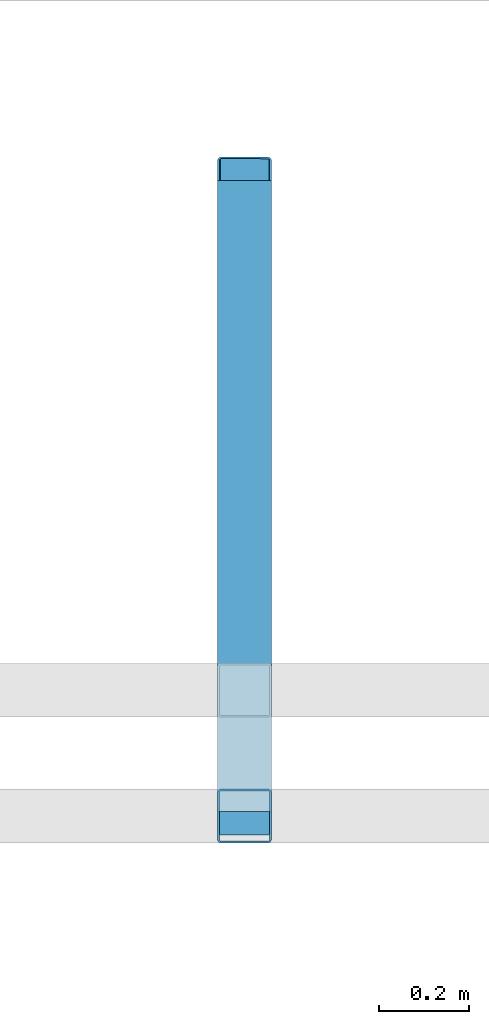
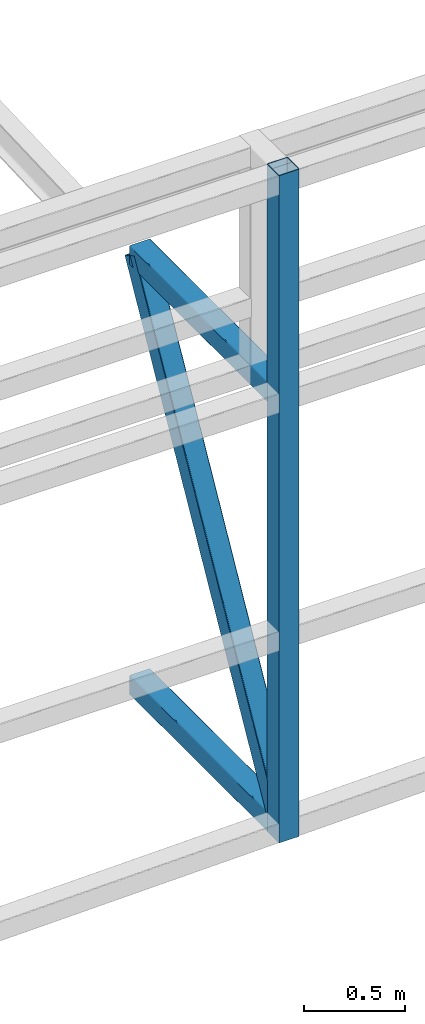
# One storey, part 107 of 215: 3 beams, 1 member, 4 elements without a shape of their own.
"""IFC2X3 building model written with IfcOpenShell, lengths in millimetres."""

from ifc_helpers import new_model, si_unit, frame, origin_with_axes, origin_2d_with_axis, place, context, subcontext, project, spatial, hollow_rectangle, extrude, material, type_object, element, aggregate, save


model = new_model("IFC2X3")

# Units and contexts
model_context = context("Model", 3, precision=1e-05, world=origin_with_axes())
body_context = subcontext(model_context, "Body", "Model", "MODEL_VIEW")
ifc_project = project(units=[si_unit("LENGTHUNIT", "METRE", prefix="MILLI"), si_unit("AREAUNIT", "SQUARE_METRE"), si_unit("VOLUMEUNIT", "CUBIC_METRE"), si_unit("MASSUNIT", "GRAM", prefix="KILO"), si_unit("TIMEUNIT", "SECOND"), si_unit("PLANEANGLEUNIT", "RADIAN"), si_unit("SOLIDANGLEUNIT", "STERADIAN"), si_unit("THERMODYNAMICTEMPERATUREUNIT", "DEGREE_CELSIUS"), si_unit("LUMINOUSINTENSITYUNIT", "LUMEN")], contexts=[model_context])

# Site, building, storey
site_placement = place(None, origin_with_axes())
site = spatial("IfcSite", under=ifc_project, at=site_placement, CompositionType="ELEMENT")
building_placement = place(site_placement, origin_with_axes())
building = spatial("IfcBuilding", under=site, at=building_placement, Name="Undefined", CompositionType="ELEMENT")
storey_placement = place(building_placement, origin_with_axes())
storey = spatial("IfcBuildingStorey", under=building, at=storey_placement, Name="Undefined", CompositionType="ELEMENT", Elevation=0.0)

# Assembly, beam
assembly_1_placement = place(storey_placement, origin_with_axes())
assembly_1 = element("IfcElementAssembly", 1, at=assembly_1_placement, inside=storey, Name="Steel Assembly", AssemblyPlace="NOTDEFINED", PredefinedType="RIGID_FRAME")
ifc_material = material(Name="STEEL/S275JR")
beam_type = type_object("IfcBeamType", PredefinedType="NOTDEFINED")
beam_1_placement = place(assembly_1_placement, frame((114285.008663075, 34554.8886083884, 371.98948395341), z_axis=(0.0, 0.0, 1.0), x_axis=(-6.93889390390723e-18, -1.0, -3.46944695195361e-18)))
beam_1 = element("IfcBeam", 2, at=beam_1_placement, type_object=beam_type, material=ifc_material, Name="LISSE", context=body_context, shape_type="SweptSolid", body=[
    extrude(hollow_rectangle(XDim=120.0, YDim=120.0, WallThickness=4.0, InnerFilletRadius=4.0, OuterFilletRadius=8.0, at=origin_2d_with_axis()), frame((1404.9181154153, 1.48751491493898e-19, -2.84217094304217e-14), z_axis=(-1.0, 0.0, 0.0), x_axis=(-6.93889390390723e-18, -1.0, -3.46944695195361e-18)), (0.0, 0.0, 1.0), 1404.9),
])
aggregate(assembly_1, [beam_1])

assembly_2_placement = place(storey_placement, origin_with_axes())
assembly_2 = element("IfcElementAssembly", 3, at=assembly_2_placement, inside=storey, Name="Steel Assembly", AssemblyPlace="NOTDEFINED", PredefinedType="RIGID_FRAME")
beam_2_placement = place(assembly_2_placement, frame((114285.010071047, 34554.8852021408, 2963.99602185051), z_axis=(0.0, 0.0, -1.0), x_axis=(-4.41999996209638e-07, -0.999999999999642, 7.22000000069896e-07)))
beam_2 = element("IfcBeam", 4, at=beam_2_placement, type_object=beam_type, material=ifc_material, Name="LISSE", context=body_context, shape_type="SweptSolid", body=[
    extrude(hollow_rectangle(XDim=120.0, YDim=120.0, WallThickness=4.0, InnerFilletRadius=4.0, OuterFilletRadius=8.0, at=origin_2d_with_axis()), frame((1404.89231313232, 5.39143026605448e-20, -1.48748759570922e-19), z_axis=(-1.0, 0.0, 0.0), x_axis=(-6.93889390390723e-18, -1.0, -3.46944695195361e-18)), (0.0, 0.0, 1.0), 1404.9),
])
aggregate(assembly_2, [beam_2])

assembly_3_placement = place(storey_placement, origin_with_axes())
assembly_3 = element("IfcElementAssembly", 5, at=assembly_3_placement, inside=storey, Name="Steel Assembly", AssemblyPlace="NOTDEFINED", PredefinedType="RIGID_FRAME")
beam_3_placement = place(assembly_3_placement, frame((114285.00956658, 33139.9261903665, 4339.19097151604), z_axis=(1.91399999311775e-06, -0.999999999998168, 0.0), x_axis=(0.0, 0.0, -1.0)))
beam_3 = element("IfcBeam", 6, at=beam_3_placement, type_object=beam_type, material=ifc_material, Name="LISSE", context=body_context, shape_type="SweptSolid", body=[
    extrude(hollow_rectangle(XDim=120.0, YDim=120.0, WallThickness=4.0, InnerFilletRadius=4.0, OuterFilletRadius=8.0, at=origin_2d_with_axis()), frame((4025.86058045271, 0.0, 0.0), z_axis=(-1.0, 0.0, 0.0), x_axis=(-6.93889390390723e-18, -1.0, -3.46944695195361e-18)), (0.0, 0.0, 1.0), 4025.9),
])
aggregate(assembly_3, [beam_3])

# Assembly, member
assembly_4_placement = place(storey_placement, origin_with_axes())
assembly_4 = element("IfcElementAssembly", 7, at=assembly_4_placement, inside=storey, Name="Steel Assembly", AssemblyPlace="NOTDEFINED", PredefinedType="RIGID_FRAME")
member_type = type_object("IfcMemberType", PredefinedType="NOTDEFINED")
member_placement = place(assembly_4_placement, frame((114285.007911522, 33149.9704265111, 431.989476453406), z_axis=(-0.00107319400015944, -0.874413990132458, 0.485179371073495), x_axis=(2.66700000248715e-06, 0.485179648022652, 0.874414495040826)))
member = element("IfcMember", 8, at=member_placement, type_object=member_type, material=ifc_material, Name="LISSE", context=body_context, shape_type="SweptSolid", body=[
    extrude(hollow_rectangle(XDim=120.0, YDim=120.0, WallThickness=4.0, InnerFilletRadius=4.0, OuterFilletRadius=8.0, at=origin_2d_with_axis()), frame((2895.65939113418, 0.0, 0.0), z_axis=(-1.0, 0.0, 0.0), x_axis=(-6.93889390390723e-18, -1.0, -3.46944695195361e-18)), (0.0, 0.0, 1.0), 2895.7),
])
aggregate(assembly_4, [member])

save(model, "model.ifc")
